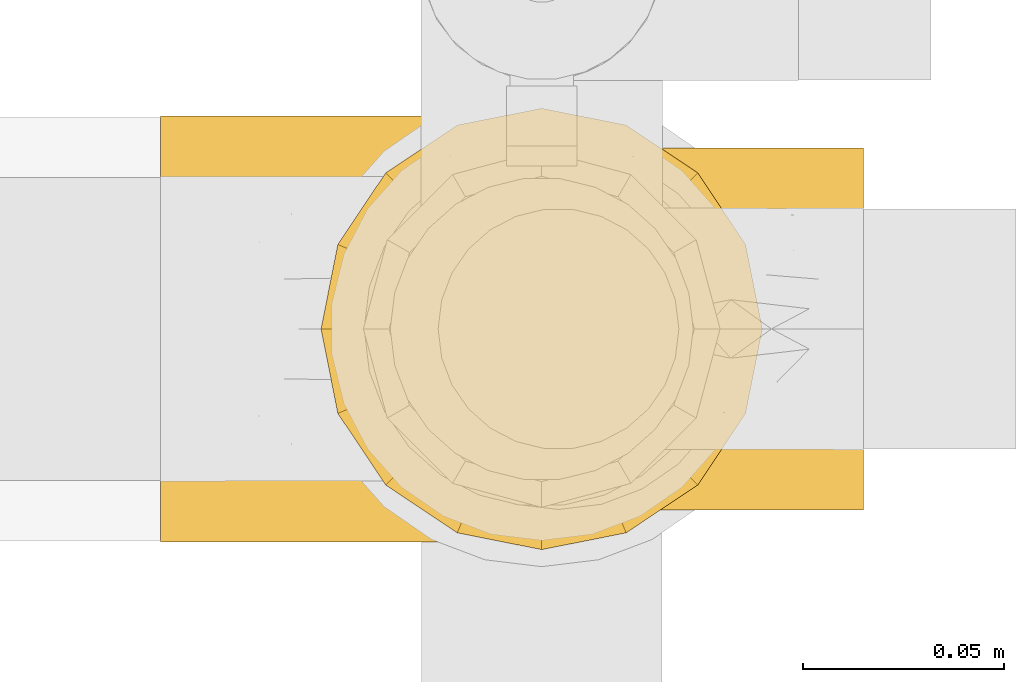
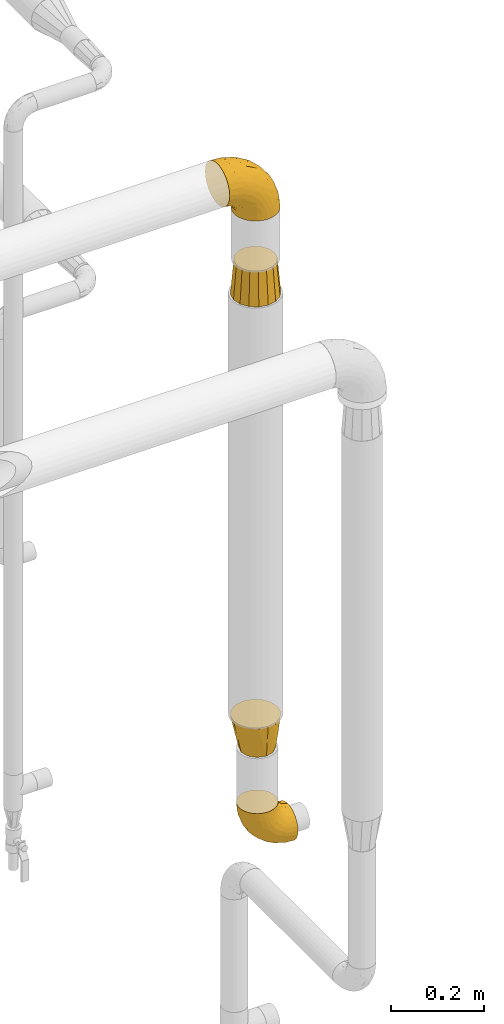
# One storey, part 138 of 827: 4 coverings.
"""IFC2X3 building model written with IfcOpenShell, lengths in millimetres."""

from ifc_helpers import new_model, entity, si_unit, converted_unit, derived_unit, direction, frame, origin, place, context, subcontext, project, spatial, faceted_brep, element, save


model = new_model("IFC2X3")

# Units and contexts
model_context = context("Model", 3, precision=0.01, world=origin(), true_north=direction((6.12303176911189e-17, 1.0)))
body_context = subcontext(model_context, "Body", "Model", "MODEL_VIEW")
ifc_project = project(units=[si_unit("LENGTHUNIT", "METRE", prefix="MILLI"), si_unit("AREAUNIT", "SQUARE_METRE"), si_unit("VOLUMEUNIT", "CUBIC_METRE"), converted_unit("PLANEANGLEUNIT", "DEGREE", entity("IfcRatioMeasure", 0.0174532925199433), si_unit("PLANEANGLEUNIT", "RADIAN"), dimensions=[0, 0, 0, 0, 0, 0, 0]), si_unit("MASSUNIT", "GRAM", prefix="KILO"), derived_unit("MASSDENSITYUNIT", [(si_unit("MASSUNIT", "GRAM", prefix="KILO"), 1), (si_unit("LENGTHUNIT", "METRE"), -3)]), derived_unit("MOMENTOFINERTIAUNIT", [(si_unit("LENGTHUNIT", "METRE"), 4)]), si_unit("TIMEUNIT", "SECOND"), si_unit("FREQUENCYUNIT", "HERTZ"), si_unit("THERMODYNAMICTEMPERATUREUNIT", "DEGREE_CELSIUS"), derived_unit("THERMALTRANSMITTANCEUNIT", [(si_unit("MASSUNIT", "GRAM", prefix="KILO"), 1), (si_unit("THERMODYNAMICTEMPERATUREUNIT", "KELVIN"), -1), (si_unit("TIMEUNIT", "SECOND"), -3)]), derived_unit("VOLUMETRICFLOWRATEUNIT", [(si_unit("LENGTHUNIT", "METRE"), 3), (si_unit("TIMEUNIT", "SECOND"), -1)]), derived_unit("MASSFLOWRATEUNIT", [(si_unit("MASSUNIT", "GRAM", prefix="KILO"), 1), (si_unit("TIMEUNIT", "SECOND"), -1)]), derived_unit("ROTATIONALFREQUENCYUNIT", [(si_unit("TIMEUNIT", "SECOND"), -1)]), si_unit("ELECTRICCURRENTUNIT", "AMPERE"), si_unit("ELECTRICVOLTAGEUNIT", "VOLT"), si_unit("POWERUNIT", "WATT"), si_unit("FORCEUNIT", "NEWTON", prefix="KILO"), si_unit("ILLUMINANCEUNIT", "LUX"), si_unit("LUMINOUSFLUXUNIT", "LUMEN"), si_unit("LUMINOUSINTENSITYUNIT", "CANDELA"), derived_unit("USERDEFINED", [(si_unit("MASSUNIT", "GRAM", prefix="KILO"), -1), (si_unit("LENGTHUNIT", "METRE"), -2), (si_unit("TIMEUNIT", "SECOND"), 3), (si_unit("LUMINOUSFLUXUNIT", "LUMEN"), 1)]), derived_unit("LINEARVELOCITYUNIT", [(si_unit("LENGTHUNIT", "METRE"), 1), (si_unit("TIMEUNIT", "SECOND"), -1)]), si_unit("PRESSUREUNIT", "PASCAL"), derived_unit("USERDEFINED", [(si_unit("LENGTHUNIT", "METRE"), -2), (si_unit("MASSUNIT", "GRAM", prefix="KILO"), 1), (si_unit("TIMEUNIT", "SECOND"), -2)]), derived_unit("LINEARFORCEUNIT", [(si_unit("MASSUNIT", "GRAM", prefix="KILO"), 1), (si_unit("LENGTHUNIT", "METRE"), 1), (si_unit("TIMEUNIT", "SECOND"), -2), (si_unit("LENGTHUNIT", "METRE"), -1)]), derived_unit("PLANARFORCEUNIT", [(si_unit("MASSUNIT", "GRAM", prefix="KILO"), 1), (si_unit("LENGTHUNIT", "METRE"), 1), (si_unit("TIMEUNIT", "SECOND"), -2), (si_unit("LENGTHUNIT", "METRE"), -2)])], contexts=[model_context])

# Site, building, storey
site_placement = place(None, origin())
site = spatial("IfcSite", under=ifc_project, at=site_placement, CompositionType="ELEMENT")
building_placement = place(site_placement, origin())
building = spatial("IfcBuilding", under=site, at=building_placement, CompositionType="ELEMENT")
storey_placement = place(building_placement, frame((0.0, 0.0, 28200.0)))
storey = spatial("IfcBuildingStorey", under=building, at=storey_placement, Name="08", CompositionType="ELEMENT", Elevation=28200.0)

# Coverings
covering_1_placement = place(storey_placement, frame((22626.89, 15360.5, 1013.71)))
element("IfcCovering", 1, at=covering_1_placement, inside=storey, Name=":ADSK_", ObjectType=":ADSK_", PredefinedType="INSULATION", context=body_context, shape_type="Brep", body=[
    faceted_brep([(36.69, 90.76, 122.75), (27.15, 87.42, 122.75), (18.59, 82.04, 122.75), (11.44, 74.89, 122.75), (6.06, 66.33, 122.75), (2.73, 56.79, 122.75), (1.6, 46.75, 122.75), (2.73, 36.69, 122.75), (6.07, 27.15, 122.75), (11.45, 18.59, 122.75), (18.6, 11.44, 122.75), (27.16, 6.06, 122.75), (36.7, 2.73, 122.75), (46.75, 1.6, 122.75), (56.8, 2.73, 122.75), (66.34, 6.07, 122.75), (74.9, 11.45, 122.75), (82.05, 18.6, 122.75), (87.43, 27.16, 122.75), (90.76, 36.7, 122.75), (91.9, 46.75, 122.75), (90.76, 56.8, 122.75), (87.42, 66.34, 122.75), (82.04, 74.9, 122.75), (74.89, 82.05, 122.75), (66.33, 87.43, 122.75), (56.79, 90.76, 122.75), (46.75, 91.9, 122.75), (122.75, 35.06, 90.36), (122.75, 24.17, 85.85), (122.75, 14.82, 78.67), (122.75, 7.64, 69.32), (122.75, 3.13, 58.43), (122.75, 1.6, 46.75), (122.75, 3.13, 35.06), (122.75, 7.64, 24.17), (122.75, 14.82, 14.82), (122.75, 24.17, 7.64), (122.75, 35.06, 3.13), (122.75, 46.75, 1.6), (122.75, 58.43, 3.13), (122.75, 69.32, 7.64), (122.75, 78.67, 14.82), (122.75, 85.85, 24.17), (122.75, 90.36, 35.06), (122.75, 91.9, 46.75), (122.75, 90.36, 58.43), (122.75, 85.85, 69.32), (122.75, 78.67, 78.67), (122.75, 69.32, 85.85), (122.75, 58.43, 90.36), (122.75, 46.75, 91.9), (24.73, 46.75, 51.54), (29.08, 55.2, 47.17), (38.13, 46.75, 38.13), (85.31, 46.75, 7.52), (93.59, 54.53, 5.85), (100.54, 46.75, 5.11), (63.54, 59.63, 19.2), (38.98, 62.07, 38.98), (50.71, 71.86, 35.02), (93.33, 62.65, 8.21), (75.2, 71.33, 19.28), (100.46, 72.93, 12.19), (41.6, 91.2, 101.39), (80.86, 86.31, 34.43), (94.87, 80.89, 20.95), (67.96, 79.49, 30.74), (52.16, 90.68, 72.93), (52.1, 86.84, 56.64), (36.74, 87.38, 80.81), (17.11, 76.87, 93.43), (23.24, 83.73, 100.76), (29.18, 81.03, 74.27), (52.53, 91.9, 93.66), (60.77, 91.9, 81.33), (69.01, 91.9, 69.01), (100.68, 91.03, 40.87), (103.79, 87.58, 29.38), (16.37, 56.52, 67.05), (7.52, 46.75, 85.31), (7.31, 60.4, 93.68), (93.66, 91.9, 52.53), (102.83, 91.9, 50.71), (112.01, 91.9, 48.88), (18.17, 67.87, 72.77), (71.97, 90.35, 51.21), (9.83, 69.57, 101.18), (5.11, 46.75, 100.54), (45.97, 79.91, 48.74), (48.88, 91.9, 112.01), (50.71, 91.9, 102.83), (22.83, 74.99, 73.88), (51.54, 46.75, 24.73), (81.33, 91.9, 60.77), (31.74, 88.53, 103.08), (32.48, 72.65, 54.8), (68.42, 46.75, 16.13), (25.33, 62.97, 55.92), (16.13, 46.75, 68.42), (92.29, 66.2, 104.98), (94.12, 56.6, 108.58), (100.97, 59.89, 98.21), (95.91, 90.95, 61.56), (107.9, 90.22, 60.69), (87.24, 76.64, 100.0), (95.46, 71.58, 95.88), (90.41, 79.99, 90.81), (74.17, 89.54, 84.88), (83.77, 89.97, 73.29), (76.72, 81.32, 113.4), (84.44, 74.56, 109.8), (76.42, 84.15, 102.13), (90.07, 90.37, 67.29), (99.69, 87.82, 70.34), (61.74, 90.98, 95.15), (58.16, 90.96, 105.49), (112.6, 85.14, 71.5), (110.45, 58.11, 92.87), (107.32, 46.75, 96.03), (108.48, 78.39, 81.34), (66.63, 88.22, 107.44), (115.23, 66.06, 88.36), (105.79, 68.6, 90.43), (89.6, 63.78, 114.37), (69.39, 88.42, 98.41), (66.99, 90.61, 88.73), (102.31, 83.8, 76.89), (99.54, 77.98, 86.08), (55.27, 91.22, 112.64), (82.03, 83.46, 94.21), (94.71, 46.75, 112.22), (96.03, 46.75, 107.32), (94.11, 84.66, 79.95), (84.21, 86.33, 84.51), (101.67, 46.75, 101.67), (112.22, 46.75, 94.71), (108.48, 15.1, 81.34), (102.31, 9.69, 76.89), (99.54, 15.52, 86.08), (94.11, 8.83, 79.96), (110.46, 35.39, 92.87), (76.74, 12.18, 113.41), (50.71, 1.6, 102.83), (58.17, 2.53, 105.5), (55.27, 2.27, 112.64), (94.12, 36.9, 108.58), (92.3, 27.31, 104.98), (100.98, 33.62, 98.2), (69.41, 5.07, 98.4), (76.44, 9.36, 102.13), (66.65, 5.27, 107.44), (115.24, 27.43, 88.36), (102.83, 1.6, 50.71), (112.01, 1.6, 48.88), (82.05, 10.05, 94.22), (87.25, 16.87, 100.01), (112.6, 8.35, 71.5), (107.9, 3.27, 60.69), (93.66, 1.6, 52.53), (95.48, 21.94, 95.89), (89.6, 29.72, 114.37), (60.77, 1.6, 81.33), (69.01, 1.6, 69.01), (74.17, 3.96, 84.88), (48.88, 1.6, 112.01), (84.45, 18.95, 109.8), (95.91, 2.54, 61.56), (90.07, 3.12, 67.29), (81.33, 1.6, 60.77), (61.75, 2.51, 95.14), (83.77, 3.52, 73.29), (84.21, 7.17, 84.53), (52.53, 1.6, 93.66), (90.42, 13.52, 90.82), (67.0, 2.88, 88.73), (99.69, 5.67, 70.34), (105.8, 24.89, 90.43), (94.87, 12.6, 20.95), (80.86, 7.18, 34.43), (67.95, 14.0, 30.74), (75.17, 22.16, 19.29), (50.65, 21.61, 35.07), (71.97, 3.14, 51.21), (52.08, 6.65, 56.67), (32.46, 20.82, 54.85), (38.98, 31.41, 38.98), (103.79, 5.91, 29.38), (100.68, 2.46, 40.87), (63.54, 33.87, 19.2), (93.32, 30.84, 8.21), (93.59, 38.96, 5.85), (100.44, 20.56, 12.19), (52.17, 2.81, 72.93), (36.75, 6.1, 80.83), (41.61, 2.29, 101.39), (7.31, 33.08, 93.69), (17.12, 16.61, 93.43), (16.37, 36.96, 67.04), (23.26, 9.75, 100.76), (18.17, 25.61, 72.78), (25.33, 30.5, 55.93), (9.84, 23.91, 101.18), (29.19, 12.45, 74.27), (22.84, 18.49, 73.89), (31.75, 4.96, 103.09), (45.96, 13.56, 48.78), (29.07, 38.28, 47.19)], [[[0, 1, 2, 3, 4, 5, 6, 7, 8, 9, 10, 11, 12, 13, 14, 15, 16, 17, 18, 19, 20, 21, 22, 23, 24, 25, 26, 27]], [[28, 29, 30, 31, 32, 33, 34, 35, 36, 37, 38, 39, 40, 41, 42, 43, 44, 45, 46, 47, 48, 49, 50, 51]], [[52, 53, 54]], [[55, 56, 57]], [[58, 59, 60]], [[61, 62, 63]], [[27, 64, 0]], [[65, 66, 67]], [[41, 40, 61]], [[68, 69, 70]], [[66, 43, 42]], [[63, 42, 41]], [[71, 72, 73]], [[72, 2, 1]], [[68, 74, 75, 76]], [[45, 44, 77]], [[43, 78, 44]], [[79, 80, 81]], [[77, 82, 83, 84, 45]], [[79, 81, 85]], [[71, 2, 72]], [[65, 86, 77]], [[4, 81, 5]], [[66, 65, 78]], [[4, 3, 87]], [[81, 88, 5]], [[63, 66, 42]], [[68, 70, 64]], [[67, 60, 89]], [[71, 3, 2]], [[64, 27, 90, 91, 74]], [[92, 71, 73]], [[40, 57, 56]], [[59, 93, 54]], [[86, 76, 94, 82]], [[1, 0, 95]], [[58, 62, 61]], [[60, 96, 89]], [[85, 81, 87]], [[56, 97, 58]], [[65, 67, 69]], [[87, 81, 4]], [[67, 89, 69]], [[61, 63, 41]], [[95, 72, 1]], [[73, 72, 70]], [[69, 73, 70]], [[73, 89, 96]], [[3, 71, 87]], [[85, 87, 71]], [[58, 61, 56]], [[59, 58, 93]], [[76, 86, 68]], [[69, 89, 73]], [[68, 86, 69]], [[65, 69, 86]], [[68, 64, 74]], [[95, 64, 70]], [[98, 79, 85]], [[79, 52, 99, 80]], [[66, 62, 67]], [[62, 58, 60]], [[62, 60, 67]], [[59, 98, 96]], [[59, 96, 60]], [[96, 85, 92]], [[88, 81, 80]], [[88, 6, 5]], [[66, 63, 62]], [[64, 95, 0]], [[72, 95, 70]], [[77, 44, 78]], [[86, 82, 77]], [[40, 39, 57]], [[96, 98, 85]], [[40, 56, 61]], [[66, 78, 43]], [[77, 78, 65]], [[79, 98, 53]], [[96, 92, 73]], [[85, 71, 92]], [[97, 56, 55]], [[97, 93, 58]], [[53, 98, 59]], [[54, 53, 59]], [[79, 53, 52]], [[100, 101, 102]], [[46, 45, 84, 83]], [[103, 104, 82]], [[82, 104, 83]], [[105, 106, 107]], [[108, 109, 76]], [[110, 111, 112]], [[103, 113, 114]], [[115, 74, 116]], [[48, 47, 117]], [[118, 102, 119]], [[49, 48, 120]], [[74, 91, 116]], [[116, 121, 115]], [[49, 122, 50]], [[123, 106, 102]], [[124, 111, 22]], [[125, 126, 115]], [[23, 22, 111]], [[24, 110, 121]], [[120, 127, 128]], [[90, 26, 129]], [[27, 26, 90]], [[121, 125, 115]], [[24, 121, 25]], [[130, 105, 107]], [[129, 25, 116]], [[21, 20, 131]], [[120, 123, 122]], [[112, 105, 130]], [[50, 118, 51]], [[21, 124, 22]], [[101, 131, 132]], [[117, 120, 48]], [[24, 23, 110]], [[127, 114, 133]], [[75, 108, 76]], [[107, 134, 130]], [[133, 114, 113]], [[129, 116, 91]], [[25, 121, 116]], [[121, 112, 125]], [[75, 74, 115]], [[101, 135, 102]], [[131, 101, 21]], [[101, 100, 124]], [[128, 127, 133]], [[119, 136, 51, 118]], [[104, 47, 46]], [[83, 104, 46]], [[117, 104, 114]], [[101, 124, 21]], [[111, 124, 100]], [[102, 118, 123]], [[133, 134, 107]], [[111, 110, 23]], [[114, 104, 103]], [[94, 76, 109]], [[121, 110, 112]], [[122, 118, 50]], [[134, 109, 108]], [[133, 107, 128]], [[112, 108, 125]], [[126, 125, 108]], [[108, 75, 126]], [[75, 115, 126]], [[109, 134, 133]], [[130, 108, 112]], [[108, 130, 134]], [[105, 112, 111]], [[111, 100, 105]], [[106, 105, 100]], [[102, 106, 100]], [[128, 106, 123]], [[90, 129, 91]], [[25, 129, 26]], [[104, 117, 47]], [[117, 114, 127]], [[82, 94, 103]], [[113, 94, 109]], [[94, 113, 103]], [[133, 113, 109]], [[106, 128, 107]], [[123, 120, 128]], [[120, 122, 49]], [[118, 122, 123]], [[135, 101, 132]], [[135, 119, 102]], [[117, 127, 120]], [[30, 29, 137]], [[138, 139, 140]], [[51, 136, 119, 141]], [[142, 17, 16]], [[143, 144, 145]], [[146, 147, 148]], [[149, 150, 151]], [[152, 29, 28]], [[33, 32, 153, 154]], [[150, 155, 156]], [[157, 31, 30]], [[153, 158, 159]], [[29, 152, 137]], [[148, 141, 119]], [[156, 160, 147]], [[148, 135, 146]], [[137, 138, 157]], [[19, 161, 146]], [[162, 163, 164]], [[14, 13, 165]], [[153, 32, 158]], [[147, 161, 166]], [[18, 17, 166]], [[167, 168, 169]], [[166, 150, 156]], [[151, 150, 142]], [[151, 170, 149]], [[151, 16, 15]], [[171, 140, 172]], [[165, 143, 145]], [[173, 170, 144]], [[142, 166, 17]], [[19, 131, 20]], [[144, 170, 151]], [[18, 161, 19]], [[173, 144, 143]], [[140, 139, 174]], [[171, 164, 163]], [[164, 172, 155]], [[151, 15, 144]], [[145, 15, 14]], [[173, 162, 170]], [[149, 175, 164]], [[19, 146, 131]], [[132, 131, 146]], [[160, 148, 147]], [[159, 158, 167]], [[135, 132, 146]], [[158, 32, 31]], [[157, 158, 31]], [[167, 158, 176]], [[166, 161, 18]], [[146, 161, 147]], [[148, 177, 141]], [[171, 168, 140]], [[171, 163, 169]], [[151, 142, 16]], [[166, 142, 150]], [[152, 141, 177]], [[51, 141, 28]], [[138, 140, 176]], [[172, 140, 174]], [[175, 149, 170]], [[164, 150, 149]], [[170, 162, 175]], [[162, 164, 175]], [[155, 172, 174]], [[171, 172, 164]], [[155, 174, 156]], [[164, 155, 150]], [[160, 156, 174]], [[147, 166, 156]], [[139, 160, 174]], [[148, 160, 177]], [[15, 145, 144]], [[165, 145, 14]], [[137, 157, 30]], [[158, 157, 176]], [[168, 167, 176]], [[169, 159, 167]], [[140, 168, 176]], [[169, 168, 171]], [[137, 177, 139]], [[160, 139, 177]], [[141, 152, 28]], [[137, 152, 177]], [[148, 119, 135]], [[157, 138, 176]], [[139, 138, 137]], [[178, 179, 180]], [[181, 180, 182]], [[179, 183, 184]], [[185, 186, 182]], [[187, 188, 179]], [[188, 33, 154, 153, 159]], [[181, 189, 190]], [[35, 34, 187]], [[191, 38, 190]], [[192, 178, 181]], [[179, 184, 180]], [[192, 190, 37]], [[37, 190, 38]], [[36, 35, 178]], [[54, 93, 186]], [[35, 187, 178]], [[193, 194, 184]], [[195, 173, 143, 165, 13]], [[195, 193, 173]], [[193, 163, 162, 173]], [[13, 12, 195]], [[8, 7, 196]], [[9, 197, 10]], [[198, 80, 99, 52]], [[196, 7, 88]], [[197, 199, 10]], [[182, 189, 181]], [[200, 198, 201]], [[200, 196, 198]], [[9, 8, 202]], [[194, 199, 203]], [[192, 37, 36]], [[80, 196, 88]], [[183, 159, 169, 163]], [[188, 34, 33]], [[202, 200, 197]], [[185, 203, 204]], [[202, 8, 196]], [[10, 199, 11]], [[12, 11, 205]], [[38, 191, 57]], [[189, 97, 191]], [[203, 199, 197]], [[205, 199, 194]], [[204, 203, 197]], [[184, 203, 206]], [[200, 202, 196]], [[197, 9, 202]], [[207, 54, 186]], [[97, 55, 191]], [[194, 203, 184]], [[183, 163, 193]], [[184, 206, 180]], [[183, 193, 184]], [[205, 195, 12]], [[193, 195, 194]], [[80, 198, 196]], [[207, 186, 201]], [[182, 180, 206]], [[181, 178, 180]], [[185, 182, 206]], [[182, 186, 189]], [[203, 185, 206]], [[185, 200, 201]], [[7, 6, 88]], [[178, 192, 36]], [[190, 192, 181]], [[199, 205, 11]], [[195, 205, 194]], [[159, 183, 188]], [[179, 188, 183]], [[57, 191, 55]], [[57, 39, 38]], [[189, 191, 190]], [[188, 187, 34]], [[178, 187, 179]], [[186, 93, 189]], [[197, 200, 204]], [[185, 204, 200]], [[189, 93, 97]], [[207, 198, 52]], [[185, 201, 186]], [[198, 207, 201]], [[54, 207, 52]]]),
])
covering_2_placement = place(storey_placement, frame((22612.86, 15350.65, 1280.89)))
element("IfcCovering", 2, at=covering_2_placement, inside=storey, Name=":ADSK_", ObjectType=":ADSK_", PredefinedType="INSULATION", context=body_context, shape_type="Brep", body=[
    faceted_brep([(11.74, 26.63, 89.0), (17.7, 17.7, 89.0), (26.63, 11.74, 89.0), (35.55, 5.78, 89.0), (46.07, 3.69, 89.0), (56.6, 1.6, 89.0), (66.07, 3.48, 89.0), (77.64, 5.78, 89.0), (86.56, 11.74, 89.0), (95.49, 17.7, 89.0), (101.45, 26.63, 89.0), (107.41, 35.55, 89.0), (109.5, 46.07, 89.0), (111.6, 56.6, 89.0), (109.71, 66.07, 89.0), (107.41, 77.64, 89.0), (101.45, 86.56, 89.0), (95.49, 95.49, 89.0), (86.56, 101.45, 89.0), (77.64, 107.41, 89.0), (67.12, 109.5, 89.0), (56.6, 111.6, 89.0), (47.18, 109.72, 89.0), (35.55, 107.41, 89.0), (26.63, 101.45, 89.0), (17.7, 95.49, 89.0), (11.74, 86.56, 89.0), (5.78, 77.64, 89.0), (3.69, 67.12, 89.0), (1.6, 56.6, 89.0), (3.47, 47.18, 89.0), (5.78, 35.55, 89.0), (40.77, 21.95, 0.0), (33.45, 29.27, 0.0), (26.13, 36.6, 0.0), (23.45, 46.6, 0.0), (20.77, 56.6, 0.0), (23.45, 66.6, 0.0), (26.13, 76.6, 0.0), (33.45, 83.92, 0.0), (40.77, 91.24, 0.0), (50.77, 93.92, 0.0), (60.77, 96.6, 0.0), (70.77, 93.92, 0.0), (80.77, 91.24, 0.0), (88.1, 83.92, 0.0), (95.42, 76.6, 0.0), (98.1, 66.6, 0.0), (100.77, 56.6, 0.0), (98.1, 46.6, 0.0), (95.42, 36.6, 0.0), (88.1, 29.27, 0.0), (80.77, 21.95, 0.0), (70.77, 19.27, 0.0), (60.77, 16.6, 0.0), (50.77, 19.27, 0.0), (58.87, 9.76, 40.55), (72.03, 10.47, 47.79), (81.23, 14.35, 47.16), (58.49, 8.39, 48.67), (96.37, 27.68, 44.5), (104.79, 44.73, 45.38), (89.55, 20.49, 44.5), (101.39, 36.0, 43.84), (106.67, 56.6, 48.45), (105.7, 56.6, 40.55), (104.65, 70.09, 47.79), (100.81, 79.27, 47.16), (87.6, 94.28, 44.5), (70.51, 102.74, 45.38), (94.79, 87.46, 44.5), (79.31, 99.27, 43.84), (58.5, 104.76, 48.45), (58.88, 103.39, 40.33), (16.04, 77.19, 43.84), (21.0, 85.51, 44.5), (45.05, 102.73, 47.83), (35.92, 98.85, 47.12), (12.5, 68.46, 45.38), (27.82, 92.7, 44.5), (10.29, 56.6, 48.67), (12.08, 56.6, 40.33), (38.12, 13.92, 43.84), (29.77, 18.91, 44.5), (12.4, 43.12, 47.83), (16.31, 33.95, 47.12), (46.77, 10.45, 45.38), (22.58, 25.73, 44.5)], [[[0, 1, 2, 3, 4, 5, 6, 7, 8, 9, 10, 11, 12, 13, 14, 15, 16, 17, 18, 19, 20, 21, 22, 23, 24, 25, 26, 27, 28, 29, 30, 31]], [[32, 33, 34, 35, 36, 37, 38, 39, 40, 41, 42, 43, 44, 45, 46, 47, 48, 49, 50, 51, 52, 53, 54, 55]], [[53, 56, 54]], [[57, 53, 58]], [[6, 5, 59, 56]], [[56, 57, 6]], [[58, 7, 57]], [[60, 51, 50]], [[61, 49, 48]], [[62, 8, 58]], [[9, 62, 60]], [[10, 63, 11]], [[58, 53, 52]], [[7, 6, 57]], [[51, 60, 62]], [[51, 62, 52]], [[63, 60, 50]], [[57, 56, 53]], [[8, 7, 58]], [[63, 10, 60]], [[8, 62, 9]], [[52, 62, 58]], [[61, 63, 49]], [[64, 12, 61]], [[61, 48, 65, 64]], [[63, 50, 49]], [[63, 61, 11]], [[64, 13, 12]], [[10, 9, 60]], [[11, 61, 12]], [[47, 65, 48]], [[66, 47, 67]], [[14, 13, 64, 65]], [[65, 66, 14]], [[67, 15, 66]], [[68, 45, 44]], [[69, 43, 42]], [[70, 16, 67]], [[17, 70, 68]], [[18, 71, 19]], [[67, 47, 46]], [[15, 14, 66]], [[45, 68, 70]], [[45, 70, 46]], [[71, 68, 44]], [[66, 65, 47]], [[16, 15, 67]], [[71, 18, 68]], [[16, 70, 17]], [[46, 70, 67]], [[69, 71, 43]], [[72, 20, 69]], [[69, 42, 73, 72]], [[71, 44, 43]], [[71, 69, 19]], [[72, 21, 20]], [[18, 17, 68]], [[19, 69, 20]], [[41, 73, 42]], [[74, 75, 38]], [[22, 21, 72, 73]], [[73, 76, 22]], [[77, 23, 76]], [[75, 39, 38]], [[78, 37, 36]], [[39, 75, 79]], [[25, 79, 75]], [[26, 74, 27]], [[23, 22, 76]], [[76, 73, 41]], [[77, 41, 40]], [[39, 79, 40]], [[79, 24, 77]], [[76, 41, 77]], [[24, 23, 77]], [[74, 26, 75]], [[24, 79, 25]], [[40, 79, 77]], [[78, 74, 37]], [[80, 28, 78]], [[78, 36, 81, 80]], [[74, 38, 37]], [[74, 78, 27]], [[80, 29, 28]], [[26, 25, 75]], [[27, 78, 28]], [[35, 81, 36]], [[82, 83, 32]], [[30, 29, 80, 81]], [[81, 84, 30]], [[85, 31, 84]], [[83, 33, 32]], [[86, 55, 54]], [[33, 83, 87]], [[1, 87, 83]], [[2, 82, 3]], [[31, 30, 84]], [[84, 81, 35]], [[85, 35, 34]], [[33, 87, 34]], [[87, 0, 85]], [[84, 35, 85]], [[0, 31, 85]], [[82, 2, 83]], [[0, 87, 1]], [[34, 87, 85]], [[86, 82, 55]], [[59, 4, 86]], [[86, 54, 56, 59]], [[82, 32, 55]], [[82, 86, 3]], [[59, 5, 4]], [[2, 1, 83]], [[3, 86, 4]]]),
])
covering_3_placement = place(storey_placement, frame((22572.86, 15352.6, 2703.34)))
element("IfcCovering", 3, at=covering_3_placement, inside=storey, Name=":ADSK_", ObjectType=":ADSK_", PredefinedType="INSULATION", context=body_context, shape_type="Brep", body=[
    faceted_brep([(148.32, 66.44, 1.6), (149.65, 54.65, 1.6), (148.31, 42.84, 1.6), (144.39, 31.62, 1.6), (138.06, 21.56, 1.6), (129.66, 13.16, 1.6), (119.6, 6.84, 1.6), (108.39, 2.92, 1.6), (96.6, 1.6, 1.6), (84.79, 2.93, 1.6), (73.57, 6.85, 1.6), (63.51, 13.18, 1.6), (55.11, 21.58, 1.6), (48.79, 31.64, 1.6), (44.87, 42.85, 1.6), (43.55, 54.65, 1.6), (44.88, 66.46, 1.6), (48.8, 77.67, 1.6), (55.13, 87.73, 1.6), (63.53, 96.13, 1.6), (73.59, 102.45, 1.6), (84.8, 106.37, 1.6), (96.6, 107.7, 1.6), (108.41, 106.36, 1.6), (119.62, 102.44, 1.6), (129.68, 96.11, 1.6), (138.08, 87.71, 1.6), (144.4, 77.65, 1.6), (1.6, 40.91, 45.35), (1.6, 28.12, 50.65), (1.6, 17.13, 59.08), (1.6, 8.7, 70.07), (1.6, 3.4, 82.86), (1.6, 1.6, 96.6), (1.6, 3.4, 110.33), (1.6, 8.7, 123.12), (1.6, 17.13, 134.11), (1.6, 28.12, 142.54), (1.6, 40.91, 147.84), (1.6, 54.65, 149.65), (1.6, 68.38, 147.84), (1.6, 81.17, 142.54), (1.6, 92.16, 134.11), (1.6, 100.59, 123.12), (1.6, 105.89, 110.33), (1.6, 107.7, 96.6), (1.6, 105.89, 82.86), (1.6, 100.59, 70.07), (1.6, 92.16, 59.08), (1.6, 81.17, 50.65), (1.6, 68.38, 45.35), (1.6, 54.65, 43.55), (27.97, 85.53, 137.19), (37.09, 73.42, 141.79), (58.27, 83.77, 128.89), (27.13, 64.22, 146.54), (39.91, 54.65, 144.6), (109.11, 96.72, 69.77), (94.41, 93.36, 94.41), (110.94, 84.47, 87.22), (89.69, 71.37, 117.2), (75.62, 54.65, 129.81), (106.28, 54.65, 106.28), (60.12, 103.47, 101.45), (41.41, 100.91, 115.81), (63.22, 99.1, 109.14), (32.05, 105.43, 107.65), (52.13, 106.79, 93.36), (123.27, 89.81, 59.44), (129.32, 79.59, 63.23), (138.3, 81.29, 35.59), (62.95, 74.01, 132.3), (55.89, 64.14, 138.41), (37.4, 94.75, 126.28), (144.6, 54.65, 39.91), (142.66, 70.74, 37.44), (117.85, 68.3, 90.35), (134.01, 66.05, 65.0), (89.25, 100.73, 85.4), (103.34, 106.78, 26.66), (113.52, 103.6, 29.88), (57.43, 107.7, 78.45), (44.19, 107.7, 85.2), (30.95, 107.7, 91.95), (77.98, 106.07, 77.98), (132.66, 90.59, 29.55), (121.52, 97.43, 41.42), (86.93, 84.51, 111.13), (68.4, 93.3, 114.67), (78.45, 107.7, 57.43), (67.94, 107.7, 67.94), (94.53, 107.7, 14.64), (91.95, 107.7, 30.95), (93.36, 106.79, 52.13), (85.2, 107.7, 44.19), (101.45, 103.47, 60.12), (129.81, 54.65, 75.62), (16.27, 107.7, 94.27), (42.46, 76.99, 24.59), (40.4, 84.28, 34.69), (49.71, 91.11, 31.15), (39.4, 106.26, 75.18), (31.26, 102.6, 67.55), (27.7, 106.08, 79.36), (16.7, 106.56, 84.32), (70.67, 105.36, 40.81), (81.69, 106.74, 29.93), (16.68, 101.59, 70.24), (22.57, 54.65, 37.93), (14.26, 54.65, 40.15), (17.68, 67.71, 42.1), (19.58, 91.36, 55.38), (33.49, 94.33, 52.17), (33.01, 87.1, 44.32), (40.69, 65.84, 19.85), (40.15, 54.65, 14.26), (37.93, 54.65, 22.57), (31.04, 68.92, 34.17), (45.29, 100.82, 54.85), (23.55, 79.83, 44.63), (11.36, 77.13, 47.52), (59.1, 105.9, 59.1), (57.42, 101.53, 44.11), (68.96, 106.72, 53.21), (20.38, 97.75, 62.86), (72.46, 103.08, 20.58), (83.66, 106.39, 15.79), (60.66, 98.1, 27.67), (61.01, 95.02, 13.49), (51.85, 86.9, 18.04), (46.07, 74.42, 12.44), (30.25, 54.65, 30.25), (46.65, 105.28, 66.71), (43.0, 92.87, 42.52), (19.58, 17.93, 55.38), (72.44, 6.22, 20.57), (17.67, 41.58, 42.11), (78.45, 1.6, 57.43), (68.97, 2.57, 53.22), (70.65, 3.94, 40.81), (40.69, 43.46, 19.85), (42.45, 32.32, 24.58), (31.04, 40.38, 34.16), (42.99, 16.44, 42.5), (45.18, 8.47, 54.93), (33.46, 15.01, 52.13), (60.64, 11.21, 27.66), (57.37, 7.78, 44.12), (57.43, 1.6, 78.45), (44.19, 1.6, 85.2), (39.35, 3.04, 75.17), (16.27, 1.6, 94.27), (16.7, 2.73, 84.32), (91.95, 1.6, 30.95), (85.2, 1.6, 44.19), (81.68, 2.55, 29.98), (46.68, 3.98, 66.78), (31.26, 6.69, 67.55), (16.68, 7.7, 70.24), (27.7, 3.21, 79.36), (60.99, 14.28, 13.48), (51.84, 22.42, 18.03), (40.41, 25.02, 34.66), (49.72, 18.18, 31.14), (46.06, 34.89, 12.43), (94.53, 1.6, 14.64), (11.35, 32.17, 47.52), (33.02, 22.23, 44.28), (83.65, 2.91, 15.8), (20.38, 11.54, 62.86), (67.94, 1.6, 67.94), (23.53, 29.46, 44.64), (59.12, 3.38, 59.12), (30.95, 1.6, 91.95), (58.27, 25.52, 128.89), (27.97, 23.76, 137.19), (37.4, 14.54, 126.28), (41.41, 8.38, 115.81), (27.21, 45.07, 146.53), (37.09, 35.87, 141.79), (53.2, 45.14, 139.45), (52.13, 2.5, 93.36), (103.34, 2.51, 26.67), (113.5, 5.68, 29.87), (101.45, 5.82, 60.12), (94.41, 15.93, 94.41), (109.08, 12.54, 69.76), (110.95, 24.81, 87.19), (93.36, 2.5, 52.13), (77.98, 3.22, 77.98), (32.05, 3.86, 107.65), (64.63, 35.85, 131.74), (123.25, 19.47, 59.44), (132.65, 18.68, 29.54), (129.32, 29.68, 63.2), (139.96, 27.95, 27.9), (117.85, 40.99, 90.35), (89.69, 37.92, 117.2), (121.51, 11.85, 41.39), (63.23, 10.19, 109.14), (89.17, 8.55, 85.46), (142.66, 38.53, 37.43), (68.4, 15.99, 114.67), (86.94, 24.79, 111.12), (60.12, 5.82, 101.45), (133.2, 40.56, 65.16)], [[[0, 1, 2, 3, 4, 5, 6, 7, 8, 9, 10, 11, 12, 13, 14, 15, 16, 17, 18, 19, 20, 21, 22, 23, 24, 25, 26, 27]], [[28, 29, 30, 31, 32, 33, 34, 35, 36, 37, 38, 39, 40, 41, 42, 43, 44, 45, 46, 47, 48, 49, 50, 51]], [[52, 53, 54]], [[55, 39, 56]], [[57, 58, 59]], [[60, 61, 62]], [[63, 64, 65]], [[66, 63, 67]], [[68, 69, 70]], [[53, 71, 54]], [[41, 40, 53]], [[53, 72, 71]], [[73, 42, 52]], [[42, 41, 52]], [[74, 0, 75]], [[69, 76, 77]], [[43, 73, 64]], [[45, 44, 66]], [[57, 78, 58]], [[23, 79, 80]], [[67, 81, 82, 83]], [[67, 84, 81]], [[24, 23, 80]], [[25, 85, 26]], [[86, 85, 25]], [[42, 73, 43]], [[0, 27, 75]], [[25, 24, 86]], [[70, 26, 85]], [[0, 74, 1]], [[68, 85, 86]], [[66, 64, 63]], [[60, 59, 87]], [[54, 87, 88]], [[76, 60, 62]], [[84, 89, 90, 81]], [[79, 22, 91, 92]], [[77, 74, 75]], [[93, 92, 94, 89]], [[80, 86, 24]], [[40, 55, 53]], [[76, 59, 60]], [[93, 84, 95]], [[76, 62, 96]], [[55, 72, 53]], [[70, 27, 26]], [[75, 70, 69]], [[78, 84, 63]], [[93, 79, 92]], [[95, 86, 80]], [[77, 76, 96]], [[59, 69, 68]], [[57, 68, 86]], [[68, 57, 59]], [[59, 58, 87]], [[76, 69, 59]], [[88, 87, 58]], [[87, 54, 71]], [[86, 95, 57]], [[78, 57, 95]], [[84, 78, 95]], [[78, 63, 65]], [[58, 78, 65]], [[54, 88, 73]], [[84, 93, 89]], [[79, 95, 80]], [[79, 93, 95]], [[22, 79, 23]], [[66, 83, 97, 45]], [[84, 67, 63]], [[83, 66, 67]], [[64, 44, 43]], [[64, 66, 44]], [[65, 73, 88]], [[53, 52, 41]], [[73, 52, 54]], [[73, 65, 64]], [[65, 88, 58]], [[39, 55, 40]], [[72, 55, 56]], [[56, 61, 72]], [[60, 72, 61]], [[72, 60, 71]], [[87, 71, 60]], [[27, 70, 75]], [[68, 70, 85]], [[74, 77, 96]], [[69, 77, 75]], [[98, 99, 100]], [[46, 45, 97]], [[101, 102, 103]], [[103, 104, 83]], [[105, 94, 106]], [[107, 103, 102]], [[108, 109, 51, 110]], [[111, 112, 113]], [[114, 115, 116]], [[47, 104, 107]], [[110, 117, 108]], [[49, 48, 111]], [[102, 118, 112]], [[119, 120, 111]], [[50, 49, 120]], [[121, 122, 118]], [[105, 123, 89]], [[124, 48, 107]], [[20, 19, 125]], [[121, 81, 90]], [[117, 119, 99]], [[21, 20, 126]], [[22, 21, 91]], [[105, 125, 127]], [[110, 51, 50]], [[19, 128, 125]], [[16, 15, 115]], [[129, 98, 100]], [[126, 91, 21]], [[128, 129, 127]], [[122, 123, 105]], [[114, 117, 98]], [[17, 16, 130]], [[18, 128, 19]], [[129, 18, 17]], [[125, 106, 126]], [[115, 114, 16]], [[130, 129, 17]], [[114, 98, 130]], [[117, 116, 131, 108]], [[99, 119, 113]], [[122, 121, 123]], [[92, 126, 106]], [[105, 127, 122]], [[132, 121, 118]], [[114, 130, 16]], [[129, 130, 98]], [[50, 120, 110]], [[129, 128, 18]], [[125, 128, 127]], [[125, 126, 20]], [[91, 126, 92]], [[105, 89, 94]], [[105, 106, 125]], [[94, 92, 106]], [[100, 122, 127]], [[118, 122, 133]], [[112, 118, 133]], [[132, 118, 102]], [[132, 102, 101]], [[81, 121, 132]], [[82, 103, 83]], [[132, 101, 81]], [[104, 47, 46]], [[124, 107, 102]], [[48, 47, 107]], [[113, 112, 133]], [[112, 111, 124]], [[99, 113, 133]], [[111, 113, 119]], [[99, 133, 100]], [[117, 99, 98]], [[122, 100, 133]], [[127, 129, 100]], [[103, 82, 101]], [[81, 101, 82]], [[112, 124, 102]], [[48, 124, 111]], [[104, 103, 107]], [[46, 97, 104]], [[111, 120, 49]], [[83, 104, 97]], [[110, 120, 119]], [[117, 110, 119]], [[116, 117, 114]], [[89, 123, 90]], [[90, 123, 121]], [[30, 29, 134]], [[11, 10, 135]], [[51, 109, 108, 136]], [[137, 138, 139]], [[140, 141, 142]], [[143, 144, 145]], [[146, 139, 147]], [[148, 149, 150]], [[151, 32, 152]], [[153, 154, 155]], [[156, 150, 157]], [[158, 157, 159]], [[108, 142, 136]], [[31, 158, 152]], [[160, 161, 12]], [[162, 163, 143]], [[140, 142, 116]], [[142, 141, 162]], [[14, 164, 140]], [[14, 140, 115]], [[9, 8, 165]], [[160, 12, 11]], [[141, 164, 161]], [[13, 12, 161]], [[14, 115, 15]], [[28, 166, 29]], [[135, 139, 146]], [[141, 163, 162]], [[135, 146, 160]], [[143, 167, 162]], [[29, 166, 134]], [[116, 142, 108, 131]], [[165, 153, 168]], [[10, 9, 168]], [[168, 135, 10]], [[138, 147, 139]], [[158, 169, 157]], [[14, 13, 164]], [[116, 115, 140]], [[145, 167, 143]], [[135, 160, 11]], [[168, 153, 155]], [[138, 137, 170]], [[157, 144, 156]], [[147, 144, 143]], [[161, 164, 13]], [[140, 164, 141]], [[142, 171, 136]], [[136, 171, 166]], [[161, 160, 146]], [[165, 168, 9]], [[155, 139, 135]], [[139, 154, 137]], [[168, 155, 135]], [[139, 155, 154]], [[144, 147, 172]], [[163, 147, 143]], [[156, 144, 172]], [[157, 169, 145]], [[172, 148, 156]], [[173, 159, 149]], [[159, 157, 150]], [[152, 159, 173]], [[159, 152, 158]], [[31, 30, 158]], [[169, 30, 134]], [[157, 145, 144]], [[167, 134, 171]], [[134, 167, 145]], [[171, 142, 162]], [[162, 167, 171]], [[163, 141, 161]], [[161, 146, 163]], [[147, 163, 146]], [[148, 150, 156]], [[149, 159, 150]], [[30, 169, 158]], [[145, 169, 134]], [[151, 33, 32]], [[31, 152, 32]], [[152, 173, 151]], [[28, 51, 136]], [[134, 166, 171]], [[28, 136, 166]], [[138, 170, 172]], [[147, 138, 172]], [[148, 172, 170]], [[174, 175, 176]], [[35, 34, 177]], [[178, 179, 180]], [[181, 173, 149, 148]], [[182, 183, 184]], [[185, 186, 187]], [[188, 189, 137]], [[190, 33, 151, 173]], [[191, 179, 174]], [[34, 190, 177]], [[39, 38, 178]], [[192, 193, 194]], [[4, 3, 195]], [[175, 179, 37]], [[38, 37, 179]], [[35, 176, 36]], [[196, 62, 197]], [[181, 190, 173]], [[37, 36, 175]], [[183, 6, 198]], [[189, 148, 170, 137]], [[185, 199, 200]], [[3, 2, 201]], [[202, 185, 203]], [[8, 7, 182]], [[200, 184, 186]], [[183, 7, 6]], [[181, 189, 204]], [[200, 189, 184]], [[5, 198, 6]], [[187, 203, 185]], [[195, 3, 201]], [[205, 196, 194]], [[62, 61, 197]], [[186, 198, 192]], [[180, 179, 191]], [[2, 1, 74]], [[198, 193, 192]], [[193, 5, 4]], [[194, 193, 195]], [[2, 74, 201]], [[5, 193, 198]], [[205, 74, 96]], [[188, 137, 154, 153]], [[62, 196, 96]], [[56, 178, 180]], [[198, 184, 183]], [[184, 188, 182]], [[203, 197, 191]], [[205, 194, 201]], [[187, 192, 194]], [[192, 187, 186]], [[194, 196, 187]], [[197, 187, 196]], [[197, 203, 187]], [[202, 174, 176]], [[200, 186, 185]], [[184, 198, 186]], [[199, 185, 202]], [[189, 200, 204]], [[174, 202, 203]], [[176, 177, 199]], [[189, 181, 148]], [[190, 181, 204]], [[190, 204, 177]], [[190, 34, 33]], [[188, 153, 182]], [[189, 188, 184]], [[182, 153, 165, 8]], [[183, 182, 7]], [[199, 177, 204]], [[35, 177, 176]], [[176, 175, 36]], [[179, 175, 174]], [[200, 199, 204]], [[176, 199, 202]], [[203, 191, 174]], [[180, 197, 61]], [[197, 180, 191]], [[61, 56, 180]], [[39, 178, 56]], [[38, 179, 178]], [[194, 195, 201]], [[4, 195, 193]], [[74, 205, 201]], [[96, 196, 205]]]),
])
covering_4_placement = place(storey_placement, frame((22612.86, 15350.65, 2479.89)))
element("IfcCovering", 4, at=covering_4_placement, inside=storey, Name=":ADSK_", ObjectType=":ADSK_", PredefinedType="INSULATION", context=body_context, shape_type="Brep", body=[
    faceted_brep([(5.78, 35.55, 0.0), (4.2, 43.51, 0.0), (1.6, 56.6, 0.0), (4.2, 69.69, 0.0), (5.78, 77.64, 0.0), (11.74, 86.56, 0.0), (17.7, 95.49, 0.0), (26.63, 101.45, 0.0), (35.55, 107.41, 0.0), (43.51, 108.99, 0.0), (56.6, 111.6, 0.0), (69.69, 108.99, 0.0), (77.64, 107.41, 0.0), (86.56, 101.45, 0.0), (95.49, 95.49, 0.0), (101.45, 86.56, 0.0), (107.41, 77.64, 0.0), (108.99, 69.69, 0.0), (111.6, 56.6, 0.0), (108.99, 43.51, 0.0), (107.41, 35.55, 0.0), (101.45, 26.63, 0.0), (95.49, 17.7, 0.0), (86.56, 11.74, 0.0), (77.64, 5.78, 0.0), (69.69, 4.2, 0.0), (56.6, 1.6, 0.0), (43.51, 4.2, 0.0), (35.55, 5.78, 0.0), (26.63, 11.74, 0.0), (17.7, 17.7, 0.0), (11.74, 26.63, 0.0), (9.1, 56.6, 89.0), (10.9, 47.51, 89.0), (12.71, 38.42, 89.0), (17.86, 30.71, 89.0), (23.01, 23.01, 89.0), (30.71, 17.86, 89.0), (38.42, 12.71, 89.0), (47.51, 10.9, 89.0), (56.6, 9.1, 89.0), (65.68, 10.9, 89.0), (74.77, 12.71, 89.0), (82.48, 17.86, 89.0), (90.18, 23.01, 89.0), (95.33, 30.71, 89.0), (100.48, 38.42, 89.0), (102.29, 47.51, 89.0), (104.1, 56.6, 89.0), (102.29, 65.68, 89.0), (100.48, 74.77, 89.0), (95.33, 82.48, 89.0), (90.18, 90.18, 89.0), (82.48, 95.33, 89.0), (74.77, 100.48, 89.0), (65.68, 102.29, 89.0), (56.6, 104.1, 89.0), (47.51, 102.29, 89.0), (38.42, 100.48, 89.0), (30.71, 95.33, 89.0), (23.01, 90.18, 89.0), (17.86, 82.48, 89.0), (12.71, 74.77, 89.0), (10.9, 65.68, 89.0)], [[[0, 1, 2, 3, 4, 5, 6, 7, 8, 9, 10, 11, 12, 13, 14, 15, 16, 17, 18, 19, 20, 21, 22, 23, 24, 25, 26, 27, 28, 29, 30, 31]], [[32, 33, 34, 35, 36, 37, 38, 39, 40, 41, 42, 43, 44, 45, 46, 47, 48, 49, 50, 51, 52, 53, 54, 55, 56, 57, 58, 59, 60, 61, 62, 63]], [[54, 12, 11, 10, 56, 55]], [[52, 14, 13, 12, 54, 53]], [[50, 16, 15, 14, 52, 51]], [[49, 48, 18, 17, 16, 50]], [[46, 20, 19, 18, 48, 47]], [[44, 22, 21, 20, 46, 45]], [[42, 24, 23, 22, 44, 43]], [[41, 40, 26, 25, 24, 42]], [[38, 28, 27, 26, 40, 39]], [[36, 30, 29, 28, 38, 37]], [[34, 0, 31, 30, 36, 35]], [[33, 32, 2, 1, 0, 34]], [[62, 4, 3, 2, 32, 63]], [[60, 6, 5, 4, 62, 61]], [[58, 8, 7, 6, 60, 59]], [[57, 56, 10, 9, 8, 58]]]),
])

save(model, "model.ifc")
